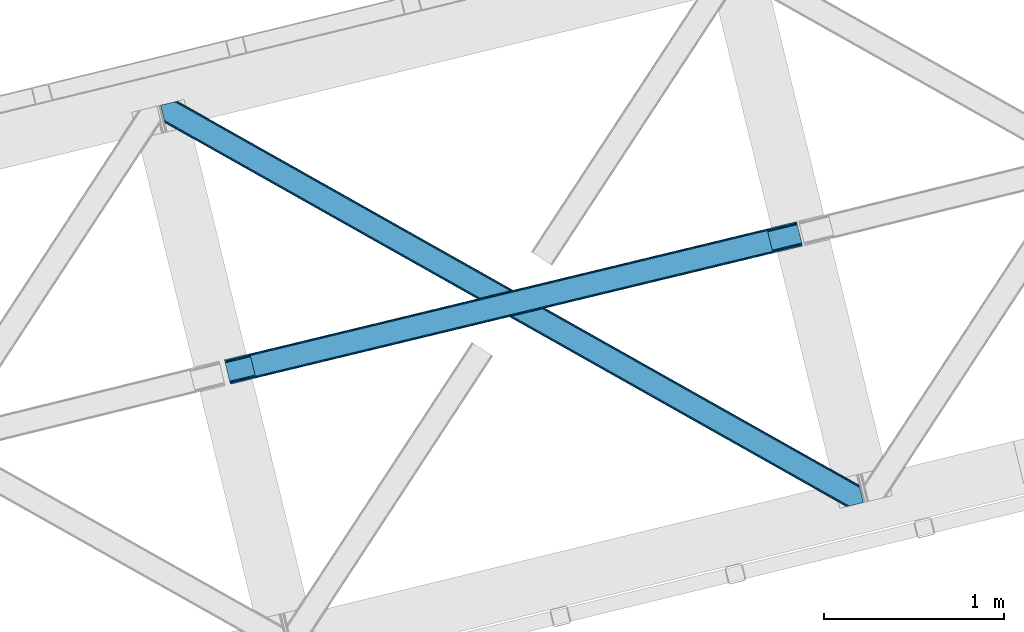
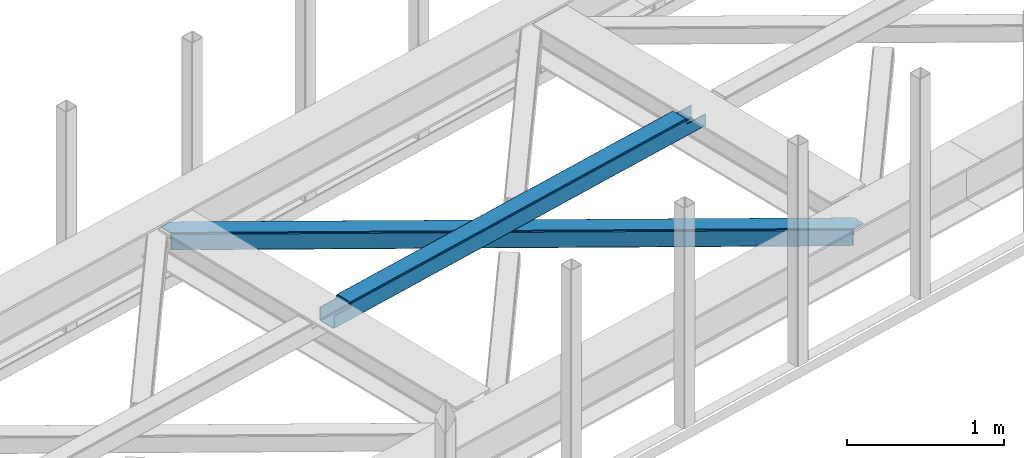
# One storey, part 28 of 67: 1 beam, 1 member.
"""IFC4 building model written with IfcOpenShell, lengths in millimetres."""

import ifcopenshell
import ifcopenshell.guid

model = None  # the IFC model being written
_history = None  # IfcOwnerHistory: only IFC2X3 demands one
_inside = {}  # id of a spatial element -> (the spatial element, [elements in it])
_under = {}  # id of a project, library or spatial element -> (it, [spatial elements below it])
_declared = {}  # id of a project -> (the project, [libraries it declares])
_typed = {}  # id of a type object -> (the type object, [elements of that type])
_made_of = {}  # id of a material, layer set ... -> (it, [elements and type objects made of it])


def new_model(schema):
    """Start an empty IFC model of exactly this schema.

    Asked for "IFC4X3", IfcOpenShell would pick the latest addendum, in which some entities
    have other attributes; the version numbers below select the first issue.
    IFC2X3 requires an IfcOwnerHistory on every rooted entity: one is made here for all.
    """
    global model, _history
    if schema == "IFC4X3":
        model = ifcopenshell.file(schema_version=(4, 3, 0, 0))
    else:
        model = ifcopenshell.file(schema=schema)
    _inside.clear()
    _under.clear()
    _declared.clear()
    _typed.clear()
    _made_of.clear()
    _history = None
    if model.schema == "IFC2X3":
        org = make("IfcOrganization", Name="unknown")
        user = make(
            "IfcPersonAndOrganization",
            ThePerson=make("IfcPerson", FamilyName="unknown"),
            TheOrganization=org,
        )
        app = make(
            "IfcApplication",
            ApplicationDeveloper=org,
            Version="unknown",
            ApplicationFullName="unknown",
            ApplicationIdentifier="unknown",
        )
        _history = make(
            "IfcOwnerHistory",
            OwningUser=user,
            OwningApplication=app,
            ChangeAction="ADDED",
            CreationDate=0,
        )
    return model


def make(cls, **values):
    """One entity of the class cls with the attributes given. An attribute that is None is left unset."""
    return model.create_entity(
        cls, **{name: value for name, value in values.items() if value is not None}
    )


def entity(cls, *values):
    """Any entity or typed value of the class cls, its attributes in the order of the schema. None: left unset."""
    e = model.create_entity(cls)
    for i, value in enumerate(values):
        if value is not None:
            e[i] = value
    return e


def rooted(cls, **values):
    """An entity with a GlobalId (a new one), such as an element, a storey or a relation."""
    return make(cls, GlobalId=ifcopenshell.guid.new(), OwnerHistory=_history, **values)


def si_unit(unit_type, name, prefix=None):
    """IfcSIUnit, for example si_unit("LENGTHUNIT", "METRE", prefix="MILLI")."""
    return make("IfcSIUnit", UnitType=unit_type, Prefix=prefix, Name=name)


def converted_unit(unit_type, name, factor, base, dimensions=None, offset=None):
    """IfcConversionBasedUnit, such as the inch: factor (a typed value) times the base unit."""
    return make(
        "IfcConversionBasedUnit"
        if offset is None
        else "IfcConversionBasedUnitWithOffset",
        ConversionOffset=offset,
        Dimensions=None
        if dimensions is None
        else entity("IfcDimensionalExponents", *dimensions),
        UnitType=unit_type,
        Name=name,
        ConversionFactor=make(
            "IfcMeasureWithUnit", ValueComponent=factor, UnitComponent=base
        ),
    )


def derived_unit(unit_type, elements):
    """IfcDerivedUnit: a product of units, each with its exponent."""
    return make(
        "IfcDerivedUnit",
        Elements=[
            make("IfcDerivedUnitElement", Unit=unit, Exponent=power)
            for unit, power in elements
        ],
        UnitType=unit_type,
    )


def assignment(units):
    """IfcUnitAssignment: the units of a project."""
    return None if units is None else make("IfcUnitAssignment", Units=units)


def point(xyz):
    """IfcCartesianPoint."""
    return None if xyz is None else make("IfcCartesianPoint", Coordinates=xyz)


def direction(xyz):
    """IfcDirection."""
    return None if xyz is None else make("IfcDirection", DirectionRatios=xyz)


def frame(location, z_axis=None, x_axis=None):
    """IfcAxis2Placement3D, a coordinate frame: its origin and axes. An axis left out is left unset."""
    return make(
        "IfcAxis2Placement3D",
        Location=point(location),
        Axis=direction(z_axis),
        RefDirection=direction(x_axis),
    )


def origin():
    """The frame at (0, 0, 0) with its axes left unset."""
    return frame((0.0, 0.0, 0.0))


def place(relative_to, where):
    """IfcLocalPlacement: puts the frame where relative to a parent placement (None: the world)."""
    return make(
        "IfcLocalPlacement", PlacementRelTo=relative_to, RelativePlacement=where
    )


def context(
    kind, dimensions, precision=None, world=None, true_north=None, identifier=None
):
    """IfcGeometricRepresentationContext, for example the 3D "Model" context."""
    return make(
        "IfcGeometricRepresentationContext",
        ContextIdentifier=identifier,
        ContextType=kind,
        CoordinateSpaceDimension=dimensions,
        Precision=precision,
        WorldCoordinateSystem=world,
        TrueNorth=true_north,
    )


def subcontext(parent, identifier, kind, view, scale=None):
    """IfcGeometricRepresentationSubContext, for example "Body" below "Model"."""
    return make(
        "IfcGeometricRepresentationSubContext",
        ContextIdentifier=identifier,
        ContextType=kind,
        ParentContext=parent,
        TargetScale=scale,
        TargetView=view,
    )


def project(units=None, contexts=None):
    """IfcProject with its units and contexts."""
    return rooted(
        "IfcProject",
        Name="project",
        RepresentationContexts=contexts,
        UnitsInContext=assignment(units),
    )


def spatial(cls, under=None, at=None, **own):
    """A site, building, storey or space (cls), placed at a placement, below another one or the project."""
    s = rooted(cls, ObjectPlacement=at, **own)
    if under is not None:
        _under.setdefault(under.id(), (under, []))[1].append(s)
    return s


def point_list(points):
    """IfcCartesianPointList2D or 3D."""
    cls = (
        "IfcCartesianPointList2D" if len(points[0]) == 2 else "IfcCartesianPointList3D"
    )
    return make(cls, CoordList=points)


def triangles(points, corners, closed=None, point_numbers=None):
    """IfcTriangulatedFaceSet: each triangle names its three corners, points numbered from 1."""
    return make(
        "IfcTriangulatedFaceSet",
        Coordinates=point_list(points),
        Closed=closed,
        CoordIndex=corners,
        PnIndex=point_numbers,
    )


def shape(context_of_items, identifier, shape_type, items):
    """IfcShapeRepresentation: the items that make up one representation, for example the "Body"."""
    return make(
        "IfcShapeRepresentation",
        ContextOfItems=context_of_items,
        RepresentationIdentifier=identifier,
        RepresentationType=shape_type,
        Items=items,
    )


def made_of(thing, what):
    """Note that an element or type object is made of a material, layer set ...; save() writes the relation."""
    if what is not None:
        _made_of.setdefault(what.id(), (what, []))[1].append(thing)
    return thing


def type_object(cls, material=None, **own):
    """A type object (cls), such as IfcWallType, which elements share."""
    return made_of(rooted(cls, **own), material)


def element(
    cls,
    number,
    at=None,
    inside=None,
    cuts=None,
    type_object=None,
    material=None,
    context=None,
    identifier="Body",
    shape_type=None,
    held_by="IfcProductDefinitionShape",
    body=None,
    shapes=None,
    **own,
):
    """One element of the class cls, such as IfcWall. Its Tag is "e" and its number.

    at: its placement. inside: the storey or other place that contains it. cuts: it is an
    opening in that element (IfcRelVoidsElement). A single representation is given by context,
    identifier, shape_type and body (its items); several are given by shapes. held_by: the class
    of the entity that holds the representations. save() writes the other relations.
    """
    e = rooted(cls, Tag="e%d" % number, ObjectPlacement=at, **own)
    if body is not None:
        shapes = [shape(context, identifier, shape_type, body)]
    if shapes is not None:
        e.Representation = make(held_by, Representations=shapes)
    if inside is not None:
        _inside.setdefault(inside.id(), (inside, []))[1].append(e)
    if cuts is not None:
        rooted(
            "IfcRelVoidsElement", RelatingBuildingElement=cuts, RelatedOpeningElement=e
        )
    if type_object is not None:
        _typed.setdefault(type_object.id(), (type_object, []))[1].append(e)
    return made_of(e, material)


def aggregate(whole, parts):
    """IfcRelAggregates: a whole, such as a stair, and the parts it consists of."""
    return rooted("IfcRelAggregates", RelatingObject=whole, RelatedObjects=parts)


def save(model, path):
    """Write the relations noted so far, then the file.

    IfcRelAggregates (storeys below a building ...), IfcRelContainedInSpatialStructure (elements
    in a storey), IfcRelDefinesByType, IfcRelAssociatesMaterial and IfcRelDeclares: one each for
    every whole, place, type object, material and project.
    """
    for whole, parts in _under.values():
        aggregate(whole, parts)
    for where, things in _inside.values():
        rooted(
            "IfcRelContainedInSpatialStructure",
            RelatedElements=things,
            RelatingStructure=where,
        )
    for kind, things in _typed.values():
        rooted("IfcRelDefinesByType", RelatedObjects=things, RelatingType=kind)
    for what, things in _made_of.values():
        rooted("IfcRelAssociatesMaterial", RelatedObjects=things, RelatingMaterial=what)
    for by, libraries in _declared.values():
        rooted("IfcRelDeclares", RelatingContext=by, RelatedDefinitions=libraries)
    model.write(path)


model = new_model("IFC4")

# Units and contexts
model_context = context("Model", 3, precision=0.01, world=origin(), true_north=direction((6.12303176911189e-17, 1.0)))
plan_context = context("Plan", 3, precision=0.01, world=origin(), true_north=direction((6.12303176911189e-17, 1.0)))
body_context = subcontext(model_context, "Body", "Model", "MODEL_VIEW")
ifc_project = project(units=[si_unit("LENGTHUNIT", "METRE", prefix="MILLI"), si_unit("AREAUNIT", "SQUARE_METRE"), si_unit("VOLUMEUNIT", "CUBIC_METRE"), converted_unit("PLANEANGLEUNIT", "DEGREE", entity("IfcRatioMeasure", 0.0174532925199433), si_unit("PLANEANGLEUNIT", "RADIAN"), dimensions=[0, 0, 0, 0, 0, 0, 0]), si_unit("MASSUNIT", "GRAM", prefix="KILO"), derived_unit("MASSDENSITYUNIT", [(si_unit("MASSUNIT", "GRAM", prefix="KILO"), 1), (si_unit("LENGTHUNIT", "METRE"), -3)]), derived_unit("MOMENTOFINERTIAUNIT", [(si_unit("LENGTHUNIT", "METRE"), 4)]), si_unit("TIMEUNIT", "SECOND"), si_unit("FREQUENCYUNIT", "HERTZ"), si_unit("THERMODYNAMICTEMPERATUREUNIT", "DEGREE_CELSIUS"), derived_unit("THERMALTRANSMITTANCEUNIT", [(si_unit("MASSUNIT", "GRAM", prefix="KILO"), 1), (si_unit("THERMODYNAMICTEMPERATUREUNIT", "KELVIN"), -1), (si_unit("TIMEUNIT", "SECOND"), -3)]), derived_unit("VOLUMETRICFLOWRATEUNIT", [(si_unit("LENGTHUNIT", "METRE"), 3), (si_unit("TIMEUNIT", "SECOND"), -1)]), derived_unit("MASSFLOWRATEUNIT", [(si_unit("MASSUNIT", "GRAM", prefix="KILO"), 1), (si_unit("TIMEUNIT", "SECOND"), -1)]), derived_unit("ROTATIONALFREQUENCYUNIT", [(si_unit("TIMEUNIT", "SECOND"), -1)]), si_unit("ELECTRICCURRENTUNIT", "AMPERE"), si_unit("ELECTRICVOLTAGEUNIT", "VOLT"), si_unit("POWERUNIT", "WATT"), si_unit("FORCEUNIT", "NEWTON", prefix="KILO"), si_unit("ILLUMINANCEUNIT", "LUX"), si_unit("LUMINOUSFLUXUNIT", "LUMEN"), si_unit("LUMINOUSINTENSITYUNIT", "CANDELA"), derived_unit("USERDEFINED", [(si_unit("MASSUNIT", "GRAM", prefix="KILO"), -1), (si_unit("LENGTHUNIT", "METRE"), -2), (si_unit("TIMEUNIT", "SECOND"), 3), (si_unit("LUMINOUSFLUXUNIT", "LUMEN"), 1)]), derived_unit("LINEARVELOCITYUNIT", [(si_unit("LENGTHUNIT", "METRE"), 1), (si_unit("TIMEUNIT", "SECOND"), -1)]), si_unit("PRESSUREUNIT", "PASCAL"), derived_unit("USERDEFINED", [(si_unit("LENGTHUNIT", "METRE"), -2), (si_unit("MASSUNIT", "GRAM", prefix="KILO"), 1), (si_unit("TIMEUNIT", "SECOND"), -2)]), derived_unit("LINEARFORCEUNIT", [(si_unit("MASSUNIT", "GRAM", prefix="KILO"), 1), (si_unit("LENGTHUNIT", "METRE"), 1), (si_unit("TIMEUNIT", "SECOND"), -2), (si_unit("LENGTHUNIT", "METRE"), -1)]), derived_unit("PLANARFORCEUNIT", [(si_unit("MASSUNIT", "GRAM", prefix="KILO"), 1), (si_unit("LENGTHUNIT", "METRE"), 1), (si_unit("TIMEUNIT", "SECOND"), -2), (si_unit("LENGTHUNIT", "METRE"), -2)])], contexts=[model_context, plan_context])

# Site, building, storey
site_placement = place(None, origin())
site = spatial("IfcSite", under=ifc_project, at=site_placement, CompositionType="ELEMENT")
building_placement = place(site_placement, origin())
building = spatial("IfcBuilding", under=site, at=building_placement, CompositionType="ELEMENT")
storey_placement = place(building_placement, frame((0.0, 0.0, 19800.0)))
storey = spatial("IfcBuildingStorey", under=building, at=storey_placement, CompositionType="ELEMENT", Elevation=19800.0)

# Beam
beam_type = type_object("IfcBeamType", PredefinedType="BEAM")
beam_placement = place(storey_placement, frame((-45771.8526489258, 7982.51624450684, 3967.02835693359)))
element("IfcBeam", 1, at=beam_placement, inside=storey, type_object=beam_type, ObjectType="Steel Beam", PredefinedType="BEAM", context=body_context, shape_type="Tessellation", body=[
    triangles([(3181.73602294922, 886.704597473145, 0.969708251952397), (3206.60427246094, 784.691638183594, 0.969708251952397), (29.012182617189, 17.0018692016602, 0.0), (4.14393310547166, 119.015409851074, 0.0), (3180.15007324219, 893.211177062989, 2.30218505859375), (2.5579833984375, 125.521989440918, 1.33247680664135), (3178.80596923828, 898.727119445801, 6.09497680663844), (1.21387939453416, 131.037350463867, 5.12526855468604), (3177.90834960938, 902.412940979004, 11.7736999511726), (0.316259765626455, 134.72317199707, 10.8016662597656), (3177.59208984375, 903.707048034668, 18.4709655761726), (0.0, 136.017279052734, 17.4989318847656), (3210.43194580078, 768.983876037597, 11.7736999511726), (3210.74820556641, 767.689187622071, 18.4709655761726), (33.1561157226606, 0.0, 17.4989318847656), (32.8398559570342, 1.29410705566443, 10.8016662597656), (3209.53432617188, 772.669116210938, 6.09497680663844), (31.9422363281265, 4.97992858886755, 5.12526855468604), (3208.19022216797, 778.18505859375, 2.30218505859375), (30.5981323242231, 10.4952896118166, 1.33247680664135), (3179.5640625, 895.611611938477, 18.7732727050789), (3177.59208984375, 903.707048034668, 100.470611572266), (3179.24780273438, 896.906300354003, 25.4705383300789), (3179.24780273438, 896.906300354003, 100.470611572266), (3180.46168212891, 891.926371765137, 13.0945495605447), (3181.81043701172, 886.410429382324, 9.3017578125), (3183.39638671876, 879.903849792481, 7.96928100585865), (3207.87396240234, 779.470445251465, 13.0945495605447), (3208.77623291016, 775.784623718262, 18.7732727050789), (3209.08784179688, 774.490516662598, 25.4705383300789), (3210.74820556641, 767.689187622071, 100.470611572266), (3209.08784179688, 774.490516662598, 100.470611572266), (3206.52985839844, 784.986387634277, 9.3017578125), (3204.94390869141, 791.492385864258, 7.96928100585865), (27.3518188476592, 23.8026168823244, 6.99957275390625), (5.79964599609957, 112.214662170411, 6.99957275390625), (1.97197265625437, 127.922424316406, 17.8035644531228), (1.65571289062791, 129.216531372071, 24.4985046386719), (2.86959228516207, 124.236602783203, 12.1248413085923), (4.21369628906541, 118.72066040039, 8.3320495605476), (28.9377685546933, 17.2966186523436, 8.3320495605476), (30.2818725585967, 11.7806762695309, 12.1248413085923), (31.1794921875044, 8.09485473632776, 17.8035644531228), (31.4957519531308, 6.80074768066424, 24.4985046386719), (3015.94614257813, 857.452894592285, 100.470611572266), (3014.29042968751, 864.254223632812, 100.470611572266), (3047.44654541016, 728.236363220214, 100.470611572266), (3045.78618164063, 735.037110900879, 100.470611572266), (0.0, 136.017279052734, 104.491296386717), (1.65571289062791, 129.216531372071, 104.491296386717), (33.1561157226606, 0.0, 104.491296386717), (31.4957519531308, 6.80074768066424, 104.491296386717), (131.908227539068, 160.684959411621, 104.491296386717), (130.25251464844, 167.485707092285, 104.491296386717), (163.408630371094, 31.4684280395504, 104.491296386717), (161.748266601564, 38.2691757202147, 104.491296386717), (135.689392089844, 161.598275756836, 106.102825927734), (134.033679199223, 168.3990234375, 106.102825927734), (139.470556640626, 162.511592102051, 107.71435546875), (137.814843750006, 169.312339782715, 107.71435546875), (141.037902832031, 162.890057373047, 111.602490234374), (139.377539062501, 169.690805053711, 111.602490234374), (142.600598144534, 163.268522644043, 115.541784667967), (140.944885253906, 170.069270324707, 115.492950439453), (174.101000976567, 34.0514099121092, 115.492950439453), (172.440637207037, 40.8527389526371, 115.541784667967), (170.877941894534, 40.4742736816406, 111.602490234374), (172.533654785162, 33.6735260009764, 111.602490234374), (170.96630859375, 33.2950607299808, 107.71435546875), (169.310595703129, 40.0958084106442, 107.71435546875), (167.189794921876, 32.3817443847656, 106.102825927734), (165.529431152347, 39.1824920654299, 106.102825927734), (3013.3183959961, 864.019354248047, 101.47287597656), (3013.3183959961, 864.019354248047, 123.420373535155), (140.944885253906, 170.069270324707, 122.541357421873), (3046.47451171876, 728.001493835449, 123.420373535155), (174.101000976567, 34.0514099121092, 122.541357421873), (3014.97410888672, 857.218606567383, 116.420800781249), (3044.81414794922, 734.802241516114, 101.47287597656), (3044.81414794922, 734.802241516114, 116.420800781249), (3013.63465576172, 862.725247192382, 130.117639160155), (141.261145019533, 168.775163269043, 129.238623046873), (3014.53227539063, 859.039425659179, 135.794036865234), (142.15876464844, 165.08934173584, 134.917346191407), (3015.87637939453, 853.523483276367, 139.586828613279), (143.502868652344, 159.573399353028, 138.710137939452), (3017.46232910157, 847.016903686523, 140.91930541992), (145.088818359378, 153.066819763184, 140.042614746093), (3042.33057861328, 745.003944396973, 140.91930541992), (169.957067871095, 51.053860473633, 140.042614746093), (3043.91652832032, 738.497364807128, 139.586828613279), (171.543017578129, 44.5472808837894, 138.710137939452), (3045.26063232422, 732.981422424316, 135.794036865234), (172.887121582033, 39.0313385009767, 134.917346191407), (3046.15825195313, 729.295600891113, 130.117639160155), (173.78474121094, 35.3455169677736, 129.238623046873), (3016.18798828125, 852.238677978516, 128.794464111328), (3017.53209228516, 846.722735595704, 132.587255859373), (3019.11804199219, 840.216156005859, 133.919732666014), (3040.67021484375, 751.804692077636, 133.919732666014), (3015.29036865235, 855.923918151855, 123.115740966798), (3014.97410888672, 857.218606567383, 101.47287597656), (3042.25616455078, 745.298112487793, 132.587255859373), (3043.60026855469, 739.78217010498, 128.794464111328), (3044.5025390625, 736.09692993164, 123.115740966798), (3046.47451171876, 728.001493835449, 101.47287597656), (143.814477539068, 158.288594055176, 127.917773437501), (142.916857910161, 161.973834228515, 122.239050292967), (146.744531250006, 146.26607208252, 133.043041992187), (168.296704101565, 57.8546081542972, 133.043041992187), (145.158581542972, 152.772651672363, 131.710565185545), (171.226757812503, 45.832086181641, 127.917773437501), (172.129028320313, 42.1468460083006, 122.239050292967), (169.8826538086, 51.3480285644528, 131.710565185545)], [[1, 2, 3], [3, 4, 1], [5, 1, 4], [4, 6, 5], [7, 5, 6], [6, 8, 7], [9, 7, 8], [8, 10, 9], [11, 9, 10], [10, 12, 11], [13, 14, 15], [15, 16, 13], [17, 13, 16], [16, 18, 17], [19, 17, 18], [18, 20, 19], [2, 19, 20], [20, 3, 2], [9, 11, 21], [22, 23, 11], [23, 22, 24], [23, 21, 11], [25, 9, 21], [25, 7, 9], [5, 25, 26], [25, 5, 7], [26, 1, 5], [1, 27, 2], [27, 1, 26], [13, 28, 29], [29, 14, 13], [29, 30, 14], [30, 31, 14], [32, 31, 30], [33, 28, 19], [2, 33, 19], [34, 2, 27], [2, 34, 33], [19, 28, 17], [17, 28, 13], [34, 27, 35], [36, 35, 27], [21, 23, 37], [38, 37, 23], [25, 21, 39], [37, 39, 21], [26, 25, 40], [39, 40, 25], [27, 26, 36], [40, 36, 26], [33, 34, 41], [35, 41, 34], [28, 33, 42], [41, 42, 33], [29, 28, 43], [42, 43, 28], [30, 29, 44], [43, 44, 29], [24, 22, 45], [46, 45, 22], [31, 32, 47], [48, 47, 32], [39, 10, 8], [39, 8, 6], [39, 6, 40], [36, 4, 3], [4, 40, 6], [36, 40, 4], [10, 37, 12], [49, 38, 50], [49, 12, 38], [10, 39, 37], [37, 38, 12], [41, 20, 42], [3, 35, 36], [41, 3, 20], [3, 41, 35], [18, 16, 42], [42, 20, 18], [16, 43, 42], [44, 43, 15], [15, 43, 16], [44, 51, 52], [15, 51, 44], [53, 54, 50], [49, 50, 54], [55, 56, 51], [52, 51, 56], [57, 58, 53], [54, 53, 58], [59, 60, 57], [58, 57, 60], [61, 62, 59], [60, 59, 62], [63, 64, 61], [62, 61, 64], [65, 66, 67], [67, 68, 65], [68, 67, 69], [70, 69, 67], [69, 70, 71], [72, 71, 70], [71, 72, 55], [56, 55, 72], [73, 62, 64], [11, 12, 73], [73, 22, 11], [64, 74, 73], [75, 74, 64], [60, 73, 12], [12, 54, 58], [12, 49, 54], [58, 60, 12], [60, 62, 73], [47, 15, 14], [76, 65, 47], [77, 65, 76], [47, 65, 68], [47, 14, 31], [15, 47, 69], [68, 69, 47], [69, 71, 15], [55, 15, 71], [15, 55, 51], [45, 38, 23], [63, 45, 78], [45, 63, 61], [45, 61, 59], [45, 23, 24], [38, 45, 59], [59, 57, 38], [53, 38, 57], [38, 53, 50], [79, 70, 67], [30, 44, 79], [79, 32, 30], [79, 66, 80], [79, 67, 66], [70, 79, 44], [44, 56, 72], [44, 52, 56], [72, 70, 44], [81, 74, 82], [75, 82, 74], [83, 81, 84], [82, 84, 81], [85, 83, 86], [84, 86, 83], [87, 85, 88], [86, 88, 85], [89, 87, 90], [88, 90, 87], [91, 89, 92], [90, 92, 89], [93, 91, 94], [92, 94, 91], [95, 93, 96], [94, 96, 93], [76, 95, 77], [96, 77, 95], [97, 81, 83], [97, 83, 85], [97, 85, 98], [99, 87, 100], [87, 98, 85], [99, 98, 87], [81, 101, 74], [73, 78, 102], [73, 74, 78], [81, 97, 101], [101, 78, 74], [103, 91, 104], [89, 100, 87], [103, 89, 91], [89, 103, 100], [93, 95, 104], [104, 91, 93], [95, 105, 104], [80, 105, 76], [76, 105, 95], [80, 106, 79], [76, 106, 80], [107, 84, 82], [75, 108, 82], [75, 64, 63], [63, 108, 75], [108, 107, 82], [107, 86, 84], [109, 110, 88], [86, 111, 88], [111, 86, 107], [111, 109, 88], [96, 94, 112], [112, 113, 96], [113, 66, 77], [113, 77, 96], [66, 65, 77], [112, 92, 114], [90, 114, 92], [110, 90, 88], [90, 110, 114], [112, 94, 92], [98, 99, 109], [109, 111, 98], [97, 98, 111], [111, 107, 97], [101, 97, 107], [107, 108, 101], [78, 101, 108], [108, 63, 78], [99, 100, 110], [110, 109, 99], [105, 80, 66], [66, 113, 105], [104, 105, 113], [113, 112, 104], [103, 104, 112], [112, 114, 103], [100, 103, 114], [114, 110, 100]]),
])

# Member
member_type = type_object("IfcMemberType", PredefinedType="BRACE")
member_placement = place(storey_placement, frame((-46126.7565673828, 7302.47054443359, 3823.99987792968)))
element("IfcMember", 2, at=member_placement, inside=storey, type_object=member_type, ObjectType="Steel Horizontal Brace", PredefinedType="BRACE", context=body_context, shape_type="Tessellation", body=[
    triangles([(3809.33957519531, 0.0, 122.499499511719), (3811.23713378907, 0.461599731444949, 129.196765136719), (23.4590332031221, 2133.54767761231, 129.196765136719), (23.8915649414048, 2131.77569274902, 122.499499511719), (3816.63215332032, 1.7772171020506, 134.87548828125), (22.231201171875, 2138.59446258545, 134.87548828125), (3824.70607910156, 3.74512023925763, 138.668280029298), (20.3894531249971, 2146.14690856934, 138.668280029298), (3834.23107910156, 6.06707153320258, 140.00075683594), (18.2174926757798, 2155.05566711426, 140.00075683594), (1916.9806640625, 1065.68146362305, 17.5012573242202), (2556.11839599609, 705.752851867675, 17.5012573242202), (3195.25147705078, 345.824240112304, 17.5012573242202), (3809.33957519531, 0.0, 17.5012573242202), (1277.84758300781, 1425.61065673828, 17.5012573242202), (638.714501953124, 1785.53868713379, 17.5012573242202), (23.8915649414048, 2131.77569274902, 17.5012573242202), (3885.46516113282, 97.721360778809, 140.00075683594), (3903.67800292969, 22.9956893920898, 140.00075683594), (69.4469238281235, 2246.70995635986, 140.00075683594), (0.0, 2229.78191986084, 140.00075683594), (3883.29320068359, 106.630700683594, 138.668280029298), (78.971923828125, 2249.03190765381, 138.668280029298), (3881.45145263672, 114.18314666748, 134.87548828125), (87.0458496093779, 2250.99981079102, 134.87548828125), (3880.21896972656, 119.229350280762, 129.196765136719), (92.4455200195298, 2252.31542816162, 129.196765136719), (3879.78643798828, 121.001335144043, 122.499499511719), (94.3384277343721, 2252.77702789307, 122.499499511719), (3265.41928710938, 466.982542419433, 17.5012573242202), (3879.78643798828, 121.001335144043, 17.5012573242202), (2626.2955078125, 826.905340576172, 17.5012573242202), (1987.17172851563, 1186.82813873291, 17.5012573242202), (708.924169921876, 1906.67315368652, 17.5012573242202), (94.3384277343721, 2252.77702789307, 17.5012573242202), (1348.04794921875, 1546.75093688965, 17.5012573242202), (82.4879882812529, 2249.88825073242, 122.197192382813), (69.01904296875, 2246.60531158447, 131.668707275392), (59.4940429687485, 2244.28336029053, 133.001184082033), (0.0, 2229.78191986084, 133.001184082033), (77.0929687500029, 2248.57321472168, 127.873590087893), (84.3808959960952, 2250.35043182373, 24.5008300781265), (77.0929687500029, 2248.57321472168, 12.1248413085959), (91.5851074218735, 2252.10613861084, 9.49942016601563), (82.4879882812529, 2249.88825073242, 17.8035644531265), (84.3808959960952, 2250.35043182373, 115.499926757813), (72.3118652343765, 2247.40816955566, 9.49942016601563), (92.0548461914077, 2252.22124786377, 10.8691040039084), (1983.48823242188, 1180.86745605469, 24.5008300781265), (3882.05606689453, 111.689694213867, 115.499926757813), (2626.78850097656, 818.593057250977, 24.5008300781265), (3270.08876953125, 456.319239807129, 24.5008300781265), (3882.05606689453, 111.689694213867, 24.5008300781265), (1340.19261474609, 1543.14127349854, 24.5008300781265), (696.892346191409, 1905.41509094238, 24.5008300781265), (3882.48859863282, 109.917709350586, 122.197192382813), (3883.72108154297, 104.870924377441, 127.873590087893), (3885.56282958984, 97.3184783935549, 131.668707275392), (3887.73479003906, 88.4097198486324, 133.001184082033), (3883.72108154297, 104.870924377441, 12.1248413085959), (3885.41865234375, 97.9004196166989, 8.52041015625218), (3880.59104003906, 117.703280639648, 8.52041015625218), (3903.67800292969, 22.9956893920898, 133.001184082033), (3882.48859863282, 109.917709350586, 17.8035644531265), (3880.37709960937, 118.591017150879, 10.9365417480476), (3844.18861083985, 8.4942489624018, 133.001184082033), (15.9478637695283, 2164.36730804443, 133.001184082033), (3834.66361083985, 6.17229766845685, 131.668707275392), (18.1198242187529, 2155.45854949951, 131.668707275392), (3826.58968505859, 4.20381317138617, 127.873590087893), (19.9615722656235, 2147.90610351562, 127.873590087893), (3821.19001464844, 2.88877716064417, 122.197192382813), (21.1894042968779, 2142.85989990234, 122.197192382813), (3819.29710693359, 2.42659606933557, 115.499926757813), (21.6219360351533, 2141.0873336792, 115.499926757813), (3208.50183105469, 346.39571685791, 24.5008300781265), (3819.29710693359, 2.42659606933557, 24.5008300781265), (2565.16435546875, 708.690463256836, 24.5008300781265), (1921.83153076172, 1070.98579101562, 24.5008300781265), (635.156579589842, 1795.57528381348, 24.5008300781265), (21.6219360351533, 2141.0873336792, 24.5008300781265), (1278.49405517578, 1433.28053741455, 24.5008300781265), (21.1894042968779, 2142.85989990234, 17.8035644531265), (23.263696289061, 2134.3505355835, 9.49942016601563), (19.9615722656235, 2147.90610351562, 12.1248413085959), (23.3706665039063, 2133.90986480713, 10.8691040039084), (18.8686157226548, 2152.37676086426, 9.49942016601563), (3826.58968505859, 4.20381317138617, 12.1248413085959), (3812.86959228515, 0.859831237792605, 8.52041015625218), (3821.19001464844, 2.88877716064417, 17.8035644531265), (3834.0403930664, 6.02056274414008, 8.52041015625218), (3811.91616210937, 0.628450012206486, 10.9365417480476), (190.667431640628, 2055.62743377686, 9.49942016601563), (195.062512207034, 2037.60120849609, 9.49942016601563), (196.076403808591, 2037.6692276001, 8.49948120117188), (196.057800292969, 2037.42389373779, 8.8831787109375), (191.295300292972, 2056.67155609131, 8.85294799804615), (195.732238769531, 2037.48144836426, 9.08316650390771), (191.351110839845, 2055.8262588501, 9.20641479492406), (195.388073730472, 2037.54365386963, 9.29943237304906), (191.011596679688, 2055.72684631348, 9.35291748046802), (191.239489746091, 2057.51627197266, 8.49948120117188), (150.921020507813, 2218.6901550293, 9.49942016601563), (155.316101074219, 2200.6645111084, 9.49942016601563), (151.251232910159, 2218.34947814941, 9.25757446289208), (155.813745117186, 2200.23721160889, 9.42500610351635), (151.609350585939, 2217.98496551514, 8.99945068359375), (156.250927734378, 2199.30471038818, 9.11804809570458), (151.96281738281, 2217.619871521, 8.74132690429906), (156.692761230472, 2198.3640701294, 8.80643920898365), (152.297680664065, 2217.27919464111, 8.49948120117188), (157.134594726565, 2197.43156890869, 8.49948120117188), (3713.61983642578, 194.649165344238, 8.52041015625218), (3708.79222412109, 214.452026367188, 8.52041015625218), (3713.26636962891, 194.529405212403, 8.40181274414135), (3708.39689941406, 214.570623779297, 8.37390747070458), (3713.06638183594, 194.460223388672, 8.3320495605476), (3708.00622558594, 214.689221191406, 8.22740478515698), (3707.9085571289, 214.477606201172, 7.87393798828271), (3713.1175415039, 193.949789428711, 8.19484863281468), (3707.80623779297, 214.265991210938, 7.52047119140843), (3713.23846435547, 192.705679321289, 7.85765991211156), (3713.36403808594, 191.464476013183, 7.52047119140843), (3264.76351318359, 465.821566772461, 10.8039916992202), (3262.90316162109, 462.516535949707, 5.12526855468968), (3260.11728515625, 457.569163513183, 1.33247680664135), (3708.58293457031, 211.087696838379, 5.59500732422021), (708.268395996092, 1905.51275939941, 10.8039916992202), (706.408044433592, 1902.2071472168, 5.12526855468968), (153.148791503903, 2213.77533874512, 5.12526855468968), (703.622167968751, 1897.26035614014, 1.33247680664135), (154.990539550781, 2206.22289276123, 1.33247680664135), (700.333996582034, 1891.42524719238, 0.0), (157.162499999999, 2197.31355285645, 0.0), (3710.29910888672, 204.051498413086, 1.33247680664135), (3712.47106933594, 195.142739868164, 0.0), (3256.83376464844, 451.73405456543, 0.0), (2625.63973388672, 825.744364929199, 10.8039916992202), (1986.51595458984, 1185.66716308594, 10.8039916992202), (1347.39217529297, 1545.58996124268, 10.8039916992202), (2623.77938232422, 822.439334106445, 5.12526855468968), (1984.65560302734, 1182.36213226318, 5.12526855468968), (1345.53182373047, 1542.28434906006, 5.12526855468968), (2620.99350585938, 817.491961669922, 1.33247680664135), (1981.8697265625, 1177.41475982666, 1.33247680664135), (1342.74594726563, 1537.3375579834, 1.33247680664135), (2617.70998535156, 811.656852722168, 0.0), (1978.58620605469, 1171.57965087891, 0.0), (1339.46242675781, 1531.50244903564, 0.0), (3746.51550292969, 55.4634750366213, 0.0), (3203.83699951172, 361.072146606445, 0.0), (2564.70391845703, 721.00133972168, 0.0), (1925.57083740235, 1080.92995147705, 0.0), (1286.43310546875, 1440.85856323242, 0.0), (647.300024414064, 1800.78717498779, 0.0), (191.211584472658, 2057.6342880249, 0.0), (3195.90725097656, 346.984634399414, 10.8039916992202), (639.365624999999, 1786.69966278076, 10.8039916992202), (641.230627441408, 1790.00527496338, 5.12526855468968), (195.225292968753, 2041.17308349609, 5.12526855468968), (3197.76760253906, 350.290246582032, 5.12526855468968), (3200.55347900391, 355.237037658691, 1.33247680664135), (3748.6874633789, 46.5547164916989, 1.33247680664135), (3752.58024902343, 34.8100845336912, 8.52041015625218), (3750.40363769532, 39.517936706543, 5.59500732422021), (3751.18033447266, 36.3402236938473, 7.52047119140843), (3752.24073486328, 35.1809921264648, 8.278564453125), (644.011853027347, 1794.95206604004, 1.33247680664135), (193.383544921875, 2048.72611083984, 1.33247680664135), (2561.42039794922, 715.165649414063, 1.33247680664135), (1922.28266601563, 1075.0948425293, 1.33247680664135), (1283.14958496093, 1435.02345428467, 1.33247680664135), (2558.63452148438, 710.218858337403, 5.12526855468968), (1919.49678955078, 1070.14747009277, 5.12526855468968), (1280.36370849609, 1430.07666320801, 5.12526855468968), (2556.76951904297, 706.913246154785, 10.8039916992202), (1917.63643798828, 1066.84243927002, 10.8039916992202), (1278.50335693359, 1426.77105102539, 10.8039916992202), (3745.62253417969, 59.1411575317379, 7.52047119140843), (3746.13878173828, 57.3430114746097, 7.90416870117406), (3746.6736328125, 56.436090087891, 8.10880737304615), (3747.30150146484, 55.3762710571291, 8.34832763671875), (3747.75263671875, 54.6129455566406, 8.52041015625218), (3211.01795654297, 350.861723327636, 12.1248413085959), (3217.09200439453, 361.644204711914, 6.99957275390625), (3213.80383300781, 355.808514404297, 8.3320495605476), (3744.24587402344, 64.7751159667969, 6.99957275390625), (643.742102050783, 1810.82377166748, 6.99957275390625), (188.941955566406, 2066.94651031494, 6.99957275390625), (637.672705078126, 1800.0412902832, 12.1248413085959), (640.458581542967, 1804.98866271973, 8.3320495605476), (635.812353515626, 1796.73625946045, 17.8035644531265), (3209.15760498047, 347.55611114502, 17.8035644531265), (2565.82012939453, 709.851438903808, 17.8035644531265), (1922.48265380859, 1072.14618530273, 17.8035644531265), (1279.14982910156, 1434.44151306152, 17.8035644531265), (2567.68048095703, 713.156469726562, 12.1248413085959), (1924.34765625, 1075.45179748535, 12.1248413085959), (1281.01018066406, 1437.74654388428, 12.1248413085959), (2570.46635742187, 718.103842163086, 8.3320495605476), (1927.12888183594, 1080.39858856201, 8.3320495605476), (1283.79605712891, 1442.69333496094, 8.3320495605476), (2573.7545288086, 723.93895111084, 6.99957275390625), (1930.41705322266, 1086.23369750977, 6.99957275390625), (1287.07957763672, 1448.52902526856, 6.99957275390625), (694.376220703125, 1900.94908447266, 12.1248413085959), (691.590344238284, 1896.00287475586, 8.3320495605476), (157.264819335935, 2196.88450927734, 8.41343994140698), (159.43212890625, 2188.00191192627, 6.99957275390625), (3261.50324707032, 441.070751953125, 6.99957275390625), (3264.79141845703, 446.905860900879, 8.3320495605476), (3714.74069824219, 185.830517578125, 6.99957275390625), (3267.57264404297, 451.852651977539, 12.1248413085959), (688.30217285156, 1890.16718444824, 6.99957275390625), (696.236572265625, 1904.25469665527, 17.8035644531265), (3269.43764648437, 455.158264160156, 17.8035644531265), (2621.49114990234, 809.18025970459, 8.3320495605476), (2618.20297851563, 803.344569396972, 6.99957275390625), (1978.19088134765, 1171.45407714844, 8.3320495605476), (1974.90270996094, 1165.61896820068, 6.99957275390625), (1331.60244140625, 1527.89278564453, 6.99957275390625), (1334.89061279297, 1533.72847595215, 8.3320495605476), (2624.27702636718, 814.12705078125, 12.1248413085959), (1980.9767578125, 1176.4008682251, 12.1248413085959), (1337.67648925781, 1538.67526702881, 12.1248413085959), (2626.13737792968, 817.432662963867, 17.8035644531265), (1982.837109375, 1179.70648040771, 17.8035644531265), (1339.53684082031, 1541.98087921143, 17.8035644531265)], [[1, 2, 3], [3, 4, 1], [2, 5, 6], [6, 3, 2], [5, 7, 8], [8, 6, 5], [7, 9, 10], [10, 8, 7], [11, 1, 4], [1, 12, 13], [11, 12, 1], [13, 14, 1], [15, 4, 16], [4, 15, 11], [17, 16, 4], [9, 18, 10], [9, 19, 18], [20, 10, 18], [21, 10, 20], [18, 22, 23], [23, 20, 18], [22, 24, 25], [25, 23, 22], [24, 26, 27], [27, 25, 24], [26, 28, 29], [29, 27, 26], [30, 28, 31], [28, 30, 32], [28, 33, 29], [33, 28, 32], [34, 35, 29], [36, 29, 33], [29, 36, 34], [37, 29, 27], [38, 23, 20], [21, 39, 20], [39, 21, 40], [39, 38, 20], [41, 23, 38], [41, 37, 25], [25, 23, 41], [27, 25, 37], [42, 35, 29], [43, 44, 45], [37, 46, 29], [43, 47, 44], [42, 45, 35], [46, 42, 29], [48, 35, 45], [45, 44, 48], [49, 50, 46], [50, 51, 52], [49, 51, 50], [52, 53, 50], [54, 46, 55], [46, 54, 49], [42, 55, 46], [50, 56, 46], [37, 46, 56], [56, 57, 37], [41, 37, 57], [57, 58, 41], [38, 41, 58], [58, 59, 38], [39, 38, 59], [57, 24, 22], [60, 61, 62], [24, 57, 56], [58, 57, 22], [58, 18, 59], [19, 59, 18], [59, 19, 63], [58, 22, 18], [31, 28, 53], [62, 64, 60], [64, 31, 53], [65, 64, 62], [65, 31, 64], [28, 50, 53], [56, 26, 24], [28, 26, 56], [50, 28, 56], [59, 66, 67], [66, 59, 63], [67, 39, 59], [40, 39, 67], [66, 68, 67], [69, 67, 68], [68, 70, 69], [71, 69, 70], [70, 72, 71], [73, 71, 72], [72, 74, 73], [75, 73, 74], [76, 74, 77], [74, 76, 78], [74, 79, 75], [79, 74, 78], [80, 81, 75], [82, 75, 79], [75, 82, 80], [83, 84, 85], [81, 4, 17], [17, 86, 83], [86, 84, 83], [83, 81, 17], [75, 4, 81], [73, 71, 6], [3, 73, 6], [3, 4, 73], [75, 73, 4], [71, 8, 6], [69, 8, 71], [87, 85, 84], [69, 67, 10], [69, 10, 8], [67, 21, 10], [67, 40, 21], [72, 1, 2], [68, 7, 9], [19, 66, 9], [66, 19, 63], [66, 68, 9], [70, 7, 68], [70, 72, 5], [5, 7, 70], [2, 5, 72], [77, 14, 1], [88, 89, 90], [72, 74, 1], [88, 91, 89], [77, 90, 14], [74, 77, 1], [92, 14, 90], [90, 89, 92], [93, 94, 84], [84, 87, 93], [95, 96, 97], [96, 98, 99], [99, 98, 100], [101, 100, 94], [94, 93, 101], [100, 101, 99], [99, 97, 96], [97, 102, 95], [103, 104, 44], [47, 44, 104], [105, 106, 104], [107, 108, 106], [109, 110, 108], [111, 112, 110], [110, 109, 111], [108, 107, 109], [106, 105, 107], [104, 103, 105], [62, 61, 113], [113, 114, 62], [115, 116, 114], [117, 118, 116], [116, 115, 117], [119, 118, 120], [121, 119, 122], [122, 123, 121], [120, 122, 119], [117, 120, 118], [114, 113, 115], [124, 30, 31], [125, 124, 118], [118, 119, 125], [119, 121, 125], [124, 65, 114], [114, 116, 124], [116, 118, 124], [65, 62, 114], [126, 125, 127], [48, 128, 103], [128, 129, 130], [130, 111, 128], [128, 109, 107], [109, 128, 111], [128, 105, 103], [105, 128, 107], [128, 48, 35], [35, 34, 128], [103, 44, 48], [129, 131, 132], [132, 130, 129], [131, 133, 134], [134, 132, 131], [135, 136, 137], [137, 126, 135], [127, 135, 126], [121, 127, 125], [31, 65, 124], [30, 124, 138], [138, 32, 30], [32, 138, 139], [139, 33, 32], [33, 139, 36], [140, 36, 139], [36, 140, 34], [128, 34, 140], [124, 125, 138], [141, 138, 125], [138, 141, 142], [142, 139, 138], [139, 142, 143], [143, 140, 139], [140, 143, 129], [129, 128, 140], [125, 126, 141], [144, 141, 126], [141, 144, 142], [145, 142, 144], [142, 145, 143], [146, 143, 145], [143, 146, 129], [131, 129, 146], [126, 137, 144], [147, 144, 137], [144, 147, 145], [148, 145, 147], [145, 148, 146], [149, 146, 148], [146, 149, 131], [133, 131, 149], [136, 150, 151], [137, 151, 147], [151, 137, 136], [148, 152, 153], [152, 147, 151], [148, 147, 152], [133, 149, 154], [153, 149, 148], [149, 153, 154], [155, 133, 154], [156, 133, 155], [134, 133, 156], [157, 92, 14], [158, 16, 17], [159, 96, 95], [158, 86, 94], [94, 159, 158], [94, 98, 159], [86, 84, 94], [95, 160, 159], [161, 162, 163], [92, 157, 164], [157, 161, 165], [165, 166, 157], [167, 164, 157], [157, 166, 167], [164, 89, 92], [163, 165, 161], [150, 163, 162], [162, 151, 150], [155, 168, 169], [169, 156, 155], [168, 159, 160], [160, 169, 168], [17, 86, 158], [14, 13, 157], [151, 162, 170], [170, 152, 151], [152, 170, 171], [171, 153, 152], [153, 171, 154], [172, 154, 171], [154, 172, 155], [168, 155, 172], [162, 161, 170], [173, 170, 161], [170, 173, 171], [174, 171, 173], [171, 174, 175], [175, 172, 171], [172, 175, 159], [159, 168, 172], [161, 157, 173], [176, 173, 157], [173, 176, 174], [177, 174, 176], [174, 177, 178], [178, 175, 174], [175, 178, 159], [158, 159, 178], [157, 13, 12], [12, 176, 157], [176, 12, 11], [11, 177, 176], [177, 11, 178], [15, 178, 11], [178, 15, 158], [16, 158, 15], [166, 179, 180], [166, 180, 181], [167, 181, 182], [167, 182, 183], [91, 89, 183], [164, 183, 89], [184, 183, 182], [88, 91, 183], [183, 184, 88], [185, 180, 179], [182, 185, 186], [182, 181, 185], [180, 185, 181], [179, 187, 185], [188, 189, 102], [93, 85, 190], [93, 87, 85], [102, 190, 191], [190, 102, 97], [97, 99, 190], [80, 192, 81], [83, 81, 192], [192, 190, 83], [85, 83, 190], [102, 191, 188], [182, 186, 184], [90, 88, 184], [184, 193, 90], [77, 90, 193], [193, 76, 77], [76, 193, 78], [194, 78, 193], [78, 194, 195], [195, 79, 78], [79, 195, 196], [196, 82, 79], [82, 196, 192], [192, 80, 82], [193, 184, 197], [197, 194, 193], [194, 197, 195], [198, 195, 197], [195, 198, 199], [199, 196, 195], [196, 199, 190], [190, 192, 196], [184, 186, 200], [200, 197, 184], [197, 200, 201], [201, 198, 197], [198, 201, 199], [202, 199, 201], [199, 202, 190], [191, 190, 202], [186, 185, 200], [203, 200, 185], [200, 203, 201], [204, 201, 203], [201, 204, 202], [205, 202, 204], [202, 205, 191], [188, 191, 205], [206, 106, 108], [108, 207, 206], [108, 110, 207], [110, 208, 207], [104, 206, 43], [43, 47, 104], [207, 208, 209], [210, 123, 122], [122, 211, 210], [122, 117, 211], [210, 212, 123], [213, 211, 117], [61, 60, 113], [213, 113, 60], [209, 214, 207], [206, 215, 45], [45, 43, 206], [215, 55, 42], [42, 45, 215], [64, 53, 216], [52, 216, 53], [60, 64, 213], [216, 213, 64], [210, 211, 217], [217, 218, 210], [218, 217, 219], [219, 220, 218], [220, 219, 221], [222, 221, 219], [221, 222, 207], [207, 214, 221], [211, 213, 217], [223, 217, 213], [217, 223, 219], [224, 219, 223], [219, 224, 222], [225, 222, 224], [222, 225, 207], [206, 207, 225], [213, 216, 226], [226, 223, 213], [223, 226, 227], [227, 224, 223], [224, 227, 228], [228, 225, 224], [225, 228, 215], [215, 206, 225], [216, 52, 51], [51, 226, 216], [226, 51, 227], [49, 227, 51], [227, 49, 228], [54, 228, 49], [228, 54, 215], [55, 215, 54], [209, 134, 189], [132, 208, 130], [208, 132, 134], [130, 208, 111], [134, 209, 208], [189, 134, 156], [169, 102, 156], [102, 169, 160], [156, 102, 189], [160, 95, 102], [136, 212, 187], [123, 127, 121], [136, 123, 212], [123, 135, 127], [123, 136, 135], [150, 136, 187], [179, 150, 187], [165, 179, 166], [179, 163, 150], [179, 165, 163], [203, 185, 210], [210, 218, 203], [218, 204, 203], [204, 218, 220], [185, 212, 210], [185, 187, 212], [214, 188, 221], [188, 214, 189], [209, 189, 214], [205, 221, 188], [220, 205, 204], [221, 205, 220]]),
])

save(model, "model.ifc")
